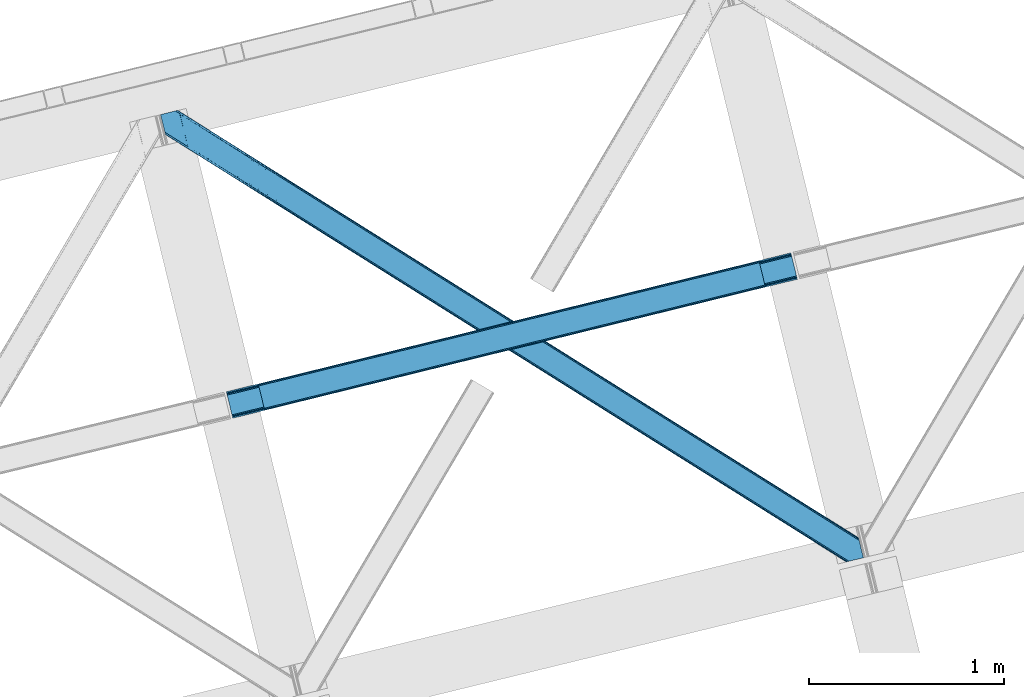
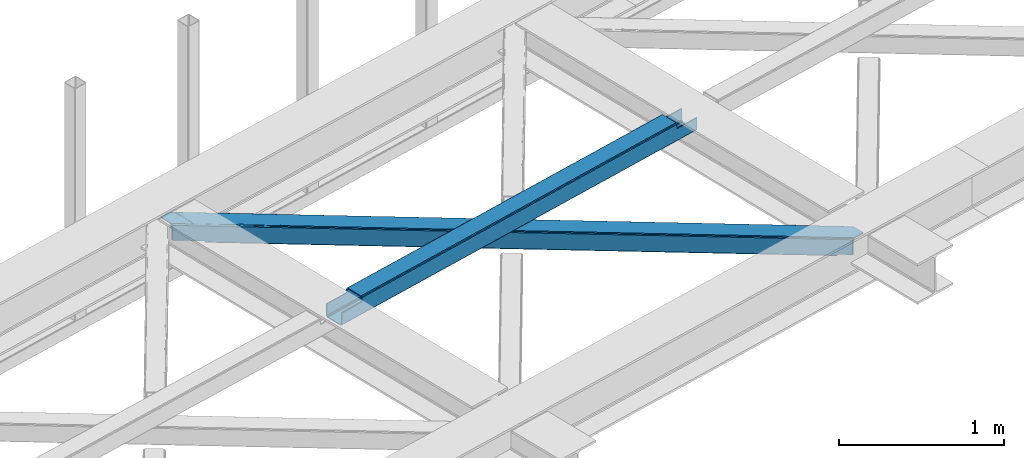
# One storey, part 22 of 67: 1 beam, 1 member.
"""IFC4 building model written with IfcOpenShell, lengths in millimetres."""

from ifc_helpers import new_model, entity, si_unit, converted_unit, derived_unit, direction, frame, origin, place, context, subcontext, project, spatial, triangles, polygons, material, type_object, element, save


model = new_model("IFC4")

# Units and contexts
model_context = context("Model", 3, precision=0.01, world=origin(), true_north=direction((6.12303176911189e-17, 1.0)))
plan_context = context("Plan", 3, precision=0.01, world=origin(), true_north=direction((6.12303176911189e-17, 1.0)))
body_context = subcontext(model_context, "Body", "Model", "MODEL_VIEW")
ifc_project = project(units=[si_unit("LENGTHUNIT", "METRE", prefix="MILLI"), si_unit("AREAUNIT", "SQUARE_METRE"), si_unit("VOLUMEUNIT", "CUBIC_METRE"), converted_unit("PLANEANGLEUNIT", "DEGREE", entity("IfcRatioMeasure", 0.0174532925199433), si_unit("PLANEANGLEUNIT", "RADIAN"), dimensions=[0, 0, 0, 0, 0, 0, 0]), si_unit("MASSUNIT", "GRAM", prefix="KILO"), derived_unit("MASSDENSITYUNIT", [(si_unit("MASSUNIT", "GRAM", prefix="KILO"), 1), (si_unit("LENGTHUNIT", "METRE"), -3)]), derived_unit("MOMENTOFINERTIAUNIT", [(si_unit("LENGTHUNIT", "METRE"), 4)]), si_unit("TIMEUNIT", "SECOND"), si_unit("FREQUENCYUNIT", "HERTZ"), si_unit("THERMODYNAMICTEMPERATUREUNIT", "DEGREE_CELSIUS"), derived_unit("THERMALTRANSMITTANCEUNIT", [(si_unit("MASSUNIT", "GRAM", prefix="KILO"), 1), (si_unit("THERMODYNAMICTEMPERATUREUNIT", "KELVIN"), -1), (si_unit("TIMEUNIT", "SECOND"), -3)]), derived_unit("VOLUMETRICFLOWRATEUNIT", [(si_unit("LENGTHUNIT", "METRE"), 3), (si_unit("TIMEUNIT", "SECOND"), -1)]), derived_unit("MASSFLOWRATEUNIT", [(si_unit("MASSUNIT", "GRAM", prefix="KILO"), 1), (si_unit("TIMEUNIT", "SECOND"), -1)]), derived_unit("ROTATIONALFREQUENCYUNIT", [(si_unit("TIMEUNIT", "SECOND"), -1)]), si_unit("ELECTRICCURRENTUNIT", "AMPERE"), si_unit("ELECTRICVOLTAGEUNIT", "VOLT"), si_unit("POWERUNIT", "WATT"), si_unit("FORCEUNIT", "NEWTON", prefix="KILO"), si_unit("ILLUMINANCEUNIT", "LUX"), si_unit("LUMINOUSFLUXUNIT", "LUMEN"), si_unit("LUMINOUSINTENSITYUNIT", "CANDELA"), derived_unit("USERDEFINED", [(si_unit("MASSUNIT", "GRAM", prefix="KILO"), -1), (si_unit("LENGTHUNIT", "METRE"), -2), (si_unit("TIMEUNIT", "SECOND"), 3), (si_unit("LUMINOUSFLUXUNIT", "LUMEN"), 1)]), derived_unit("LINEARVELOCITYUNIT", [(si_unit("LENGTHUNIT", "METRE"), 1), (si_unit("TIMEUNIT", "SECOND"), -1)]), si_unit("PRESSUREUNIT", "PASCAL"), derived_unit("USERDEFINED", [(si_unit("LENGTHUNIT", "METRE"), -2), (si_unit("MASSUNIT", "GRAM", prefix="KILO"), 1), (si_unit("TIMEUNIT", "SECOND"), -2)]), derived_unit("LINEARFORCEUNIT", [(si_unit("MASSUNIT", "GRAM", prefix="KILO"), 1), (si_unit("LENGTHUNIT", "METRE"), 1), (si_unit("TIMEUNIT", "SECOND"), -2), (si_unit("LENGTHUNIT", "METRE"), -1)]), derived_unit("PLANARFORCEUNIT", [(si_unit("MASSUNIT", "GRAM", prefix="KILO"), 1), (si_unit("LENGTHUNIT", "METRE"), 1), (si_unit("TIMEUNIT", "SECOND"), -2), (si_unit("LENGTHUNIT", "METRE"), -2)])], contexts=[model_context, plan_context])

# Site, building, storey
site_placement = place(None, origin())
site = spatial("IfcSite", under=ifc_project, at=site_placement, CompositionType="ELEMENT")
building_placement = place(site_placement, origin())
building = spatial("IfcBuilding", under=site, at=building_placement, CompositionType="ELEMENT")
storey_placement = place(building_placement, frame((0.0, 0.0, 19800.0)))
storey = spatial("IfcBuildingStorey", under=building, at=storey_placement, CompositionType="ELEMENT", Elevation=19800.0)

# Beam
ifc_material = material(Name="Metal painted (White)")
beam_type = type_object("IfcBeamType", PredefinedType="BEAM")
beam_placement = place(storey_placement, frame((-54824.1636583396, 5769.03863543557, 3967.02213739951)))
element("IfcBeam", 1, at=beam_placement, inside=storey, type_object=beam_type, material=ifc_material, ObjectType="Steel Beam", PredefinedType="BEAM", context=body_context, shape_type="Tessellation", body=[
    polygons([(195.600194800813, 47.1939241264222, 116.42075398189), (195.284716026293, 48.4881398473771, 123.117713426564), (2768.48559452429, 681.870165407988, 122.252244531349), (2768.8010732988, 680.575949687039, 115.555285086674), (194.386308486354, 52.1737543987821, 128.795119546125), (2767.58718698436, 685.555779959382, 127.92965065091), (193.041746584857, 57.68966637537, 132.588638724685), (2766.24262508285, 691.071691935976, 131.723169829474), (191.455727682833, 64.1961281805606, 133.920742055655), (2764.65660618083, 697.578153741184, 133.055273160444), (169.904498669375, 152.607589262092, 133.920675186106), (2743.10537716737, 785.989614822718, 133.055206290887), (168.318479767342, 159.11405106732, 132.588562012879), (2741.51935826533, 792.496076627927, 131.723093117668), (166.973917865845, 164.62996304391, 128.795034490451), (2740.17479636384, 798.011988604516, 127.92956559524), (166.075510325905, 168.315577595309, 123.117622795697), (2739.2763888239, 801.697603155919, 122.25215390049), (165.760031551394, 169.609793316236, 116.420661393285), (2738.9609100494, 802.991818876856, 115.55519249807), (2737.3031232022, 809.792700498515, 100.498086491912), (2737.3031232022, 809.792700498512, 122.555187727575), (2737.61860197673, 808.498484777561, 129.252149129995), (2738.51700951666, 804.812870226159, 134.929560824745), (2739.86157141815, 799.296958249569, 138.723088347173), (2741.44759032019, 792.790496444372, 140.055201520396), (2766.31439302802, 690.777272119526, 140.055278677568), (2767.90041193007, 684.270810314297, 138.723175346603), (2769.24497383155, 678.754898337704, 134.929656168038), (2770.14338137148, 675.069283786305, 129.252250048477), (2770.45886014632, 673.775068064077, 122.555290603803), (2770.458860146, 673.775068065387, 100.498086491912), (2768.8010732988, 680.575949687043, 100.498086491912), (2738.9609100494, 802.991818876859, 100.498086491912), (165.760031551394, 169.609793316234, 101.477862600484), (195.600194800804, 47.19392412642, 101.477862600484), (197.257981650611, 40.3930424941034, 101.477862600484), (197.257981647995, 40.3930425047642, 123.420759499018), (196.942502873484, 41.6872582257018, 130.117718943693), (196.044095333544, 45.3728727771036, 135.795125063254), (194.699533432056, 50.8887847536925, 139.588644241814), (193.113514530023, 57.3952465589037, 140.920747572779), (168.246711822184, 159.408470883749, 140.920670415607), (166.660692920151, 165.91493268896, 139.588557242389), (165.316131018655, 171.430844665549, 135.795029719961), (164.417723478715, 175.116459216949, 130.117618025206), (164.102244704213, 176.410674937892, 123.420656622786), (164.102244704204, 176.410674937891, 101.477862600484), (2932.90331800302, 720.968992071854, 99.4980864919168), (2932.90331800301, 720.968992071855, 24.5000861794985), (31.4979500966005, 6.80088174161364, 25.4759431828536), (31.4979500966005, 6.80088174161039, 100.477862600484), (194.629175601386, 46.954912041303, 100.477862600484), (1.65778684719041, 129.216750931428, 25.4758505942489), (2903.0631547536, 843.38486126167, 24.4999935908851), (2903.06315475361, 843.384861261669, 99.4980864919168), (2739.93192924883, 803.230830961977, 99.4980864919125), (1.65778684719041, 129.216750931425, 100.477862600484), (2934.56110484841, 714.168110457476, 17.5000909499932), (2934.56110485024, 714.168110450053, 99.4980864919168), (2771.42987934576, 674.014080149109, 99.4980864919125), (33.1557369624336, 4.30807858720073e-08, 100.477862600484), (33.1557369474987, 1.04891924479489e-07, 18.4759479533483), (2901.40536790643, 850.185742883325, 99.4980864919125), (2901.40536790642, 850.185742883325, 17.4999880737653), (-8.66293703438714e-12, 136.017632553082, 18.4758450771204), (-8.66293703438714e-12, 136.017632553081, 100.477862600484), (163.131225504786, 176.171662852774, 100.477862600484), (2769.77209249823, 680.814961772162, 99.4980864919168), (2738.27414240164, 810.031712583632, 99.4980864919125), (2903.37863352811, 842.090645540732, 17.8030341462194), (2904.27704106805, 838.405030989331, 12.125628026654), (2905.62160296955, 832.88911901274, 8.33210884809829), (2907.20762187157, 826.382657207531, 7.00000551712847), (2928.75885088503, 737.971196125998, 7.00007238668162), (2930.34486978706, 731.464734320788, 8.33218555990442), (2931.68943168856, 725.948822344197, 12.1257130823282), (2932.5878392285, 722.263207792796, 17.8031247770826), (2934.24562607568, 715.46232617116, 10.8031295475774), (2933.34721853574, 719.147940722563, 5.12571785282298), (2932.00265663425, 724.663852699151, 1.33219033039485), (2930.41663773223, 731.170314504341, 7.715717638348e-05), (2905.54983502439, 833.183538829187, 4.33146851719357e-12), (2903.96381612235, 839.690000634412, 1.33210333096982), (2902.61925422086, 845.205912611001, 5.12562250952989), (2901.72084668092, 848.891527162403, 10.8030286290909), (196.286962448568, 40.1540304196461, 100.477862600484), (164.789012351976, 169.370781231118, 100.477862600484), (27.3534829786202, 23.8030857957542, 7.97592939004109), (28.9395018806444, 17.2966239905647, 9.30804256325955), (30.2840637821412, 11.7807120139757, 13.1015700856834), (31.1824713220808, 8.09509746257289, 18.7789817804377), (1.97326562169287, 127.922535210498, 18.7788911495702), (2.87167316163245, 124.236920659101, 13.1014850300135), (4.21623506312922, 118.72100868251, 9.30796585145342), (5.80225396516212, 112.214546877286, 7.9758625204836), (0.315478774519784, 134.723416832145, 11.7788856324504), (1.21388631445936, 131.037802280743, 6.10147951288935), (2.5584482159388, 125.521890304153, 2.30796033432496), (4.1444671179717, 119.015428498944, 0.975857003359465), (29.0112698258106, 17.0022041740973, 0.975934160527186), (30.5972887278435, 10.4957423688883, 2.30804733374998), (31.9418506293316, 4.97983039229717, 6.10157485618245), (32.8402581692712, 1.2942158408987, 11.7789865509282)], [[[1, 2, 3, 4]], [[2, 5, 6, 3]], [[5, 7, 8, 6]], [[7, 9, 10, 8]], [[11, 12, 10, 9]], [[11, 13, 14, 12]], [[13, 15, 16, 14]], [[15, 17, 18, 16]], [[17, 19, 20, 18]], [[21, 22, 23, 24, 25, 26, 27, 28, 29, 30, 31, 32, 33, 4, 3, 6, 8, 10, 12, 14, 16, 18, 20, 34]], [[35, 19, 17, 15, 13, 11, 9, 7, 5, 2, 1, 36, 37, 38, 39, 40, 41, 42, 43, 44, 45, 46, 47, 48]], [[42, 41, 28, 27]], [[41, 40, 29, 28]], [[40, 39, 30, 29]], [[39, 38, 31, 30]], [[27, 26, 43, 42]], [[47, 46, 23, 22]], [[46, 45, 24, 23]], [[45, 44, 25, 24]], [[44, 43, 26, 25]], [[33, 49, 50, 51, 52, 53, 1, 4]], [[54, 55, 56, 57, 20, 19, 35, 58]], [[59, 60, 61, 31, 38, 37, 62, 63]], [[64, 65, 66, 67, 68, 47, 22, 21]], [[61, 60, 49, 69]], [[64, 70, 57, 56]], [[65, 64, 56, 55, 71, 72, 73, 74, 75, 76, 77, 78, 50, 49, 60, 59, 79, 80, 81, 82, 83, 84, 85, 86]], [[87, 53, 52, 62]], [[67, 58, 88, 68]], [[89, 90, 76, 75]], [[90, 91, 77, 76]], [[91, 92, 78, 77]], [[92, 51, 50, 78]], [[54, 93, 71, 55]], [[93, 94, 72, 71]], [[94, 95, 73, 72]], [[95, 96, 74, 73]], [[89, 75, 74, 96]], [[66, 97, 98, 99, 100, 101, 102, 103, 104, 63, 62, 52, 51, 92, 91, 90, 89, 96, 95, 94, 93, 54, 58, 67]], [[63, 104, 79, 59]], [[104, 103, 80, 79]], [[103, 102, 81, 80]], [[102, 101, 82, 81]], [[100, 99, 84, 83]], [[99, 98, 85, 84]], [[98, 97, 86, 85]], [[97, 66, 65, 86]], [[83, 82, 101, 100]]], closed=False),
])

# Member
member_type = type_object("IfcMemberType", PredefinedType="BRACE")
member_placement = place(storey_placement, frame((-55162.1911010742, 5030.29760742188, 3823.99987792968)))
element("IfcMember", 2, at=member_placement, inside=storey, type_object=member_type, ObjectType="Steel Horizontal Brace", PredefinedType="BRACE", context=body_context, shape_type="Tessellation", body=[
    triangles([(207.722204589845, 2101.81647491455, 0.0), (172.045312499999, 2248.17905273438, 0.0), (3404.49451904296, 219.293591308594, 0.0), (3440.17141113281, 72.9304321289064, 0.0), (202.587634277341, 2097.1307144165, 1.33247680664135), (208.512854003908, 2098.5748123169, 0.155804443358647), (3442.44569091796, 63.5955368041996, 1.33247680664135), (3445.6640991211, 50.3934356689451, 10.8039916992202), (3446.115234375, 48.5365722656252, 17.5012573242202), (187.951318359374, 2093.56290893555, 17.5012573242202), (189.755859375, 2094.00299835205, 10.8039916992202), (3444.37580566406, 55.6814849853517, 5.12526855468968), (194.895080566406, 2095.25582885742, 5.12526855468968), (3405.09448242188, 238.005821228027, 10.8039916992202), (3400.22036132812, 236.818684387207, 5.32758178711083), (167.840917968751, 2265.42858123779, 5.12526855468968), (166.547973632813, 2270.71604919434, 10.8039916992202), (3400.29942626953, 236.497773742676, 5.1694519042976), (3402.2155883789, 228.628486633301, 1.33247680664135), (169.766381835936, 2257.51452941895, 1.33247680664135), (3406.8990234375, 238.445910644531, 17.5012573242202), (166.096838378908, 2272.57291259766, 17.5012573242202), (3401.19239501953, 237.055297851563, 18.5197998046897), (3406.8990234375, 238.445910644531, 18.5197998046897), (3400.50406494141, 236.887866210937, 18.2267944335945), (3400.82032470703, 236.964605712891, 18.4453857421868), (3400.29477539063, 236.836706542969, 17.9035583496116), (3400.22036132812, 236.818684387207, 17.5198608398459), (3402.04350585937, 231.951539611817, 18.4453857421868), (3401.8388671875, 231.936424255371, 18.1454040527351), (3401.62027587891, 231.920146179199, 17.8198425292976), (3401.61097412109, 231.919564819336, 17.8058898925774), (3401.42028808594, 231.905612182617, 17.5198608398459), (3402.49929199219, 231.698648071289, 18.5197998046897), (3586.90198974609, 125.462690734864, 18.5197998046897), (3589.64135742188, 114.236631774903, 18.5197998046897), (204.382873535156, 2097.56789703369, 12.1248413085959), (208.512854003908, 2098.5748123169, 9.69243164062573), (199.652929687501, 2096.41506042481, 17.9802978515618), (198.425097656247, 2096.11624145508, 19.5011352539077), (187.951318359374, 2093.56290893555, 19.5011352539077), (25.310083007811, 2195.64679412842, 19.5011352539077), (22.6823364257798, 2206.42171783447, 19.5011352539077), (3437.79016113281, 82.6879760742186, 6.99957275390625), (3404.59683837891, 218.870942687989, 8.3320495605476), (3402.66672363281, 226.784994506836, 12.1248413085959), (3406.87111816406, 209.536047363282, 6.99957275390625), (3443.24564208985, 60.3184112548834, 17.5198608398459), (3441.99920654297, 65.4390289306639, 12.1248413085959), (3446.115234375, 48.5365722656252, 17.5198608398459), (3440.06909179688, 73.3530807495117, 8.3320495605476), (1232.86428222656, 1574.07891998291, 6.99957275390625), (640.588806152344, 1945.82774047852, 6.99957275390625), (602.805065917964, 1862.1026184082, 6.99957275390625), (1195.07589111328, 1490.35496063232, 6.99957275390625), (1825.13975830078, 1202.32951812744, 6.99957275390625), (1787.3513671875, 1118.60788421631, 6.99957275390625), (205.340954589839, 2111.57401885986, 6.99957275390625), (174.421911621095, 2238.42150878906, 6.99957275390625), (2971.89766845703, 375.113150024415, 6.99957275390625), (3009.69071044922, 458.831295776367, 6.99957275390625), (2379.62219238281, 746.860807800294, 6.99957275390625), (2417.415234375, 830.580697631836, 6.99957275390625), (168.836206054686, 2261.33697052002, 18.501196289064), (166.096838378908, 2272.57291259766, 18.501196289064), (168.971081542964, 2260.78584136963, 17.8803039550803), (170.217517089841, 2255.67045593262, 12.1248413085959), (172.147631835935, 2247.75698547363, 8.3320495605476), (207.559423828126, 2102.47631835938, 8.8831787109375), (3444.59439697266, 58.9998870849613, 18.5197998046897), (3447.33376464844, 47.7738281250004, 18.5197998046897), (3447.04541015625, 47.9546310424803, 18.2849304199226), (3444.26883544922, 59.317890930176, 18.2802795410171), (3446.72449951171, 48.1552001953123, 18.0198303222678), (3443.92001953125, 59.6591491699219, 18.0198303222678), (3446.40358886719, 48.356350708008, 17.757055664064), (3443.63166503906, 59.9422714233397, 17.8058898925774), (3443.57120361328, 60.0009887695314, 17.7617065429695), (3534.35635986328, 2.65972137451172, 18.5197998046897), (3523.44539794922, 0.0, 18.5197998046897), (2962.59125976562, 360.290798950195, 24.5008300781265), (2963.30284423828, 361.419218444825, 17.8035644531265), (3532.92854003906, 2.31206817626935, 24.5008300781265), (2965.31667480469, 364.63239440918, 12.1248413085959), (596.224072265621, 1851.62186279297, 12.1248413085959), (599.242492675781, 1856.43029022217, 8.3320495605476), (594.21024169922, 1848.40868682861, 17.8035644531265), (593.498657226563, 1847.28026733398, 24.5008300781265), (22.9334838867144, 2205.40433807373, 24.5008300781265), (2968.33509521484, 369.440821838379, 8.3320495605476), (2370.32043457031, 732.038456726074, 24.5008300781265), (2371.02736816406, 733.16629486084, 17.8035644531265), (1778.75654296875, 1104.91395263672, 17.8035644531265), (1778.0449584961, 1103.78553314209, 24.5008300781265), (1186.48106689453, 1476.6616104126, 17.8035644531265), (1185.77413330078, 1475.53319091797, 24.5008300781265), (2373.04584960937, 736.379470825195, 12.1248413085959), (1780.77037353515, 1108.12712860107, 12.1248413085959), (1188.49954833985, 1479.87420501709, 12.1248413085959), (2376.06427001953, 741.188479614258, 8.3320495605476), (1783.78879394531, 1112.93555603027, 8.3320495605476), (1191.51796875, 1484.68321380615, 8.3320495605476), (2965.14924316406, 350.42105255127, 122.499499511719), (2371.32502441406, 723.143650817871, 122.499499511719), (3523.44539794922, 0.0, 122.499499511719), (1777.49615478516, 1095.86624908447, 122.499499511719), (1183.67193603516, 1468.58884735107, 122.499499511719), (589.843066406247, 1841.31144561768, 122.499499511719), (25.310083007811, 2195.64679412842, 122.499499511719), (3532.92854003906, 2.31206817626935, 115.499926757813), (22.9334838867144, 2205.40433807373, 115.499926757813), (3534.73308105468, 2.75215759277398, 122.197192382813), (22.4776977539077, 2207.26120147705, 122.197192382813), (3539.876953125, 4.00498809814508, 127.873590087893), (21.1894042968706, 2212.54925079346, 127.873590087893), (3547.56485595703, 5.87987365722711, 131.668707275392), (19.2592895507769, 2220.4633026123, 131.668707275392), (3556.63872070312, 8.09194793701226, 133.001184082033), (16.9850097656235, 2229.79819793701, 133.001184082033), (3525.24993896484, 0.440089416503724, 129.196765136719), (3530.38916015625, 1.69291992187482, 134.87548828125), (3547.15557861328, 5.77987976074201, 140.00075683594), (3612.21207275391, 21.6376327514654, 140.00075683594), (3612.21207275391, 21.6376327514654, 133.001184082033), (3538.08171386718, 3.56780548095685, 138.668280029298), (168.515295410158, 2261.63113861084, 18.7407165527366), (165.808483886714, 2272.75313415527, 18.7360656738274), (168.171130371091, 2261.94914245605, 19.0011657714858), (165.492224121095, 2272.95428466797, 19.0011657714858), (167.826965332031, 2262.26714630127, 19.2592895507805), (165.17131347656, 2273.15543518066, 19.2639404296897), (167.510705566405, 2262.56131439209, 19.5011352539077), (164.882958984374, 2273.33565673828, 19.5011352539077), (78.2975463867188, 2318.55673370361, 19.5011352539077), (88.7666748046831, 2321.11006622314, 19.5011352539077), (649.183630371095, 1959.52167205811, 17.8035644531265), (3018.28553466796, 472.525227355957, 17.8035644531265), (3016.26705322265, 469.312632751465, 12.1248413085959), (3018.99246826172, 473.653646850586, 24.5008300781265), (3589.2832397461, 115.705146789551, 24.5008300781265), (649.890563964844, 1960.65009155273, 24.5008300781265), (79.2835327148423, 2318.79799804688, 24.5008300781265), (3013.2486328125, 464.503623962402, 8.3320495605476), (644.146728515625, 1951.50006866455, 8.3320495605476), (647.165148925778, 1956.30849609375, 12.1248413085959), (2420.97315673828, 836.253025817871, 8.3320495605476), (1828.69768066406, 1208.00184631348, 8.3320495605476), (1236.42220458984, 1579.75124816895, 8.3320495605476), (2423.99157714844, 841.061453247071, 12.1248413085959), (1831.71610107422, 1212.81027374268, 12.1248413085959), (1239.440625, 1584.55967559815, 12.1248413085959), (2426.01005859375, 844.274629211426, 17.8035644531265), (1833.73458251953, 1216.02344970703, 17.8035644531265), (1241.45910644531, 1587.7728515625, 17.8035644531265), (2426.7169921875, 845.403048706055, 24.5008300781265), (1834.44151611328, 1217.15186920166, 24.5008300781265), (1242.16604003906, 1588.90068969727, 24.5008300781265), (1247.70988769531, 1593.6864440918, 122.499499511719), (653.815905761716, 1966.45090026855, 122.499499511719), (1841.59921875, 1220.9225692749, 122.499499511719), (3586.90198974609, 125.462690734864, 122.499499511719), (2435.4932006836, 848.158694458008, 122.499499511719), (3029.38718261719, 475.394819641114, 122.499499511719), (88.7666748046831, 2321.11006622314, 122.499499511719), (3591.02266845703, 108.560234069824, 127.873590087893), (3588.64606933593, 118.317778015137, 134.87548828125), (3590.57618408203, 110.403726196289, 138.668280029298), (3592.95278320312, 100.646182250976, 131.668707275392), (3595.22706298828, 91.3112869262695, 133.001184082033), (3592.85046386719, 101.068830871583, 140.00075683594), (3589.734375, 113.848283386231, 122.197192382813), (3587.3577758789, 123.605827331543, 129.196765136719), (3589.2832397461, 115.705146789551, 115.499926757813), (55.5733520507783, 2313.01811828613, 133.001184082033), (0.0, 2299.47185211182, 133.001184082033), (79.2835327148423, 2318.79799804688, 115.499926757813), (64.647216796875, 2315.23019256592, 131.668707275392), (72.3397705078096, 2317.105078125, 127.873590087893), (77.4789916992158, 2318.35790863037, 122.197192382813), (76.0651245117188, 2318.01316223145, 138.000878906252), (81.8229125976577, 2319.41714630127, 134.87548828125), (86.962133789064, 2320.66997680664, 129.196765136719), (0.0, 2299.47185211182, 138.000878906252), (24.8589477539063, 2197.50365753174, 129.196765136719), (23.5706542968765, 2202.79228820801, 134.87548828125), (22.1242309570298, 2208.71692657471, 138.000878906252), (98.1940063476577, 2304.12389373779, 138.000878906252), (139.391491699214, 2135.11211700439, 138.000878906252), (599.144824218747, 1856.13379669189, 140.00075683594), (139.828674316406, 2137.54627075195, 139.000817871096), (140.051916503908, 2136.3818069458, 138.668280029298), (137.847399902341, 2145.67426300049, 140.00075683594), (592.568481445313, 1845.65304107666, 134.87548828125), (139.805419921875, 2135.02549438477, 138.075292968751), (595.586901855466, 1850.46146850586, 138.668280029298), (139.921691894531, 2135.65975799561, 138.352020263672), (140.037963867188, 2136.29576568604, 138.631072998047), (2974.45565185547, 365.243403625488, 140.00075683594), (2970.89307861328, 359.571075439453, 138.668280029298), (2967.87465820312, 354.762648010254, 134.87548828125), (2965.86082763672, 351.549472045898, 129.196765136719), (590.549999999996, 1842.4398651123, 129.196765136719), (2372.03195800781, 724.272070312501, 129.196765136719), (1778.2030883789, 1096.9946685791, 129.196765136719), (1184.3788696289, 1469.7172668457, 129.196765136719), (2374.05043945312, 727.485246276856, 134.87548828125), (1780.22156982421, 1100.20784454346, 134.87548828125), (1186.39270019531, 1472.93044281006, 134.87548828125), (2377.06885986328, 732.293673706055, 138.668280029298), (1783.23999023438, 1105.01627197266, 138.668280029298), (1189.41112060547, 1477.73887023926, 138.668280029298), (2380.62678222656, 737.96600189209, 140.00075683594), (1786.79791259766, 1110.68860015869, 140.00075683594), (1192.97369384766, 1483.41119842529, 140.00075683594), (651.090490722658, 1962.10930480957, 134.87548828125), (98.7102539062471, 2303.62683105469, 138.075292968751), (99.1985961914033, 2302.47515716553, 138.384576416018), (648.072070312497, 1957.30087738037, 138.668280029298), (99.6032226562456, 2301.53800506592, 138.633398437501), (644.514147949216, 1951.62854919434, 140.00075683594), (100.189233398436, 2300.16483306885, 139.000817871096), (102.170507812501, 2292.03684082031, 140.00075683594), (3028.68024902343, 474.266400146485, 129.196765136719), (3026.66176757812, 471.053224182129, 134.87548828125), (3023.64334716797, 466.24479675293, 138.668280029298), (3020.08542480469, 460.572468566895, 140.00075683594), (653.108972167967, 1965.32248077393, 129.196765136719), (2429.74936523438, 839.008671569824, 138.668280029298), (2426.1914428711, 833.336343383789, 140.00075683594), (1835.86003417968, 1211.77254638672, 138.668280029298), (1832.2974609375, 1206.10021820068, 140.00075683594), (1241.96605224609, 1584.53700256348, 138.668280029298), (1238.40347900391, 1578.86467437744, 140.00075683594), (2432.76778564453, 843.817680358887, 134.87548828125), (1838.87845458985, 1216.58155517578, 134.87548828125), (1244.98447265625, 1589.34542999268, 134.87548828125), (2434.78626708984, 847.030274963379, 129.196765136719), (1840.89228515625, 1219.79473114014, 129.196765136719), (1247.00295410156, 1592.55860595703, 129.196765136719)], [[1, 2, 3], [3, 4, 1], [5, 6, 4], [4, 7, 5], [8, 9, 10], [10, 11, 8], [12, 8, 11], [11, 13, 12], [7, 12, 13], [13, 5, 7], [6, 1, 4], [14, 15, 16], [16, 17, 14], [18, 19, 20], [19, 3, 2], [2, 20, 19], [20, 16, 18], [15, 18, 16], [21, 14, 17], [17, 22, 21], [23, 21, 24], [25, 23, 26], [23, 25, 27], [23, 27, 28], [21, 23, 28], [28, 15, 14], [14, 21, 28], [26, 29, 30], [25, 30, 31], [27, 32, 33], [27, 31, 32], [33, 28, 27], [31, 27, 25], [30, 25, 26], [23, 34, 29], [29, 26, 23], [34, 24, 35], [24, 34, 23], [35, 36, 34], [37, 38, 5], [37, 5, 13], [13, 11, 39], [38, 6, 5], [39, 37, 13], [11, 10, 40], [41, 40, 10], [11, 40, 39], [42, 43, 40], [40, 41, 42], [3, 44, 4], [45, 19, 46], [33, 15, 28], [18, 33, 46], [33, 18, 15], [3, 19, 45], [46, 19, 18], [3, 47, 44], [45, 47, 3], [8, 48, 9], [48, 12, 49], [12, 48, 8], [50, 9, 48], [49, 7, 51], [51, 4, 44], [4, 51, 7], [49, 12, 7], [52, 53, 54], [54, 55, 52], [55, 56, 52], [56, 55, 57], [53, 58, 54], [53, 59, 58], [60, 61, 62], [61, 60, 47], [44, 47, 60], [63, 62, 61], [57, 63, 56], [62, 63, 57], [17, 22, 64], [22, 65, 64], [66, 17, 64], [66, 16, 17], [67, 16, 66], [20, 67, 68], [67, 20, 16], [2, 20, 68], [68, 59, 2], [69, 38, 6], [69, 1, 58], [1, 59, 58], [59, 1, 2], [69, 6, 1], [70, 71, 72], [72, 73, 70], [73, 72, 74], [74, 75, 73], [75, 76, 77], [75, 74, 76], [76, 78, 77], [78, 76, 50], [50, 48, 78], [71, 70, 79], [79, 80, 71], [81, 70, 73], [73, 82, 81], [73, 75, 82], [75, 77, 82], [83, 79, 70], [70, 81, 83], [82, 77, 78], [78, 84, 82], [78, 48, 84], [48, 49, 84], [54, 58, 69], [85, 86, 38], [86, 69, 38], [87, 85, 37], [88, 87, 39], [39, 40, 88], [88, 40, 89], [43, 89, 40], [37, 39, 87], [38, 37, 85], [69, 86, 54], [51, 44, 90], [60, 90, 44], [49, 51, 84], [90, 84, 51], [81, 82, 91], [92, 91, 82], [91, 92, 93], [93, 94, 91], [94, 93, 95], [95, 96, 94], [96, 95, 87], [87, 88, 96], [82, 84, 97], [97, 92, 82], [92, 97, 98], [98, 93, 92], [93, 98, 99], [99, 95, 93], [95, 99, 85], [85, 87, 95], [84, 90, 100], [100, 97, 84], [97, 100, 101], [101, 98, 97], [98, 101, 102], [102, 99, 98], [99, 102, 86], [86, 85, 99], [90, 60, 62], [62, 100, 90], [100, 62, 57], [57, 101, 100], [101, 57, 55], [55, 102, 101], [102, 55, 54], [54, 86, 102], [9, 103, 104], [71, 105, 72], [71, 80, 105], [105, 74, 72], [50, 105, 103], [50, 76, 105], [76, 74, 105], [9, 50, 103], [106, 10, 9], [10, 107, 108], [109, 41, 108], [106, 107, 10], [106, 9, 104], [10, 108, 41], [42, 41, 109], [81, 110, 83], [110, 81, 91], [110, 94, 111], [94, 110, 91], [88, 89, 111], [96, 111, 94], [111, 96, 88], [112, 110, 111], [111, 113, 112], [114, 112, 113], [113, 115, 114], [116, 114, 115], [115, 117, 116], [118, 116, 117], [117, 119, 118], [112, 120, 121], [118, 122, 123], [123, 124, 118], [118, 116, 122], [116, 125, 122], [114, 125, 116], [121, 125, 114], [112, 105, 120], [110, 105, 112], [121, 114, 112], [80, 83, 79], [110, 80, 105], [83, 80, 110], [65, 64, 126], [126, 127, 65], [127, 126, 128], [128, 129, 127], [129, 128, 130], [130, 131, 129], [131, 130, 132], [132, 133, 131], [134, 135, 133], [133, 132, 134], [136, 66, 67], [137, 138, 33], [138, 46, 33], [139, 29, 34], [34, 140, 139], [34, 36, 140], [139, 137, 32], [32, 31, 139], [30, 29, 139], [139, 31, 30], [141, 130, 128], [141, 132, 130], [128, 136, 141], [64, 136, 126], [128, 126, 136], [64, 66, 136], [132, 141, 142], [142, 134, 132], [33, 32, 137], [45, 46, 143], [138, 143, 46], [47, 45, 61], [143, 61, 45], [53, 144, 59], [68, 59, 144], [144, 145, 68], [67, 68, 145], [67, 145, 136], [61, 143, 63], [146, 63, 143], [63, 146, 147], [147, 56, 63], [56, 147, 148], [148, 52, 56], [52, 148, 144], [144, 53, 52], [143, 138, 146], [149, 146, 138], [146, 149, 147], [150, 147, 149], [147, 150, 148], [151, 148, 150], [148, 151, 144], [145, 144, 151], [138, 137, 152], [152, 149, 138], [149, 152, 153], [153, 150, 149], [150, 153, 154], [154, 151, 150], [151, 154, 136], [136, 145, 151], [137, 139, 152], [155, 152, 139], [152, 155, 153], [156, 153, 155], [153, 156, 154], [157, 154, 156], [154, 157, 136], [141, 136, 157], [158, 22, 159], [22, 158, 160], [161, 35, 24], [21, 160, 162], [21, 163, 24], [160, 21, 22], [24, 163, 161], [162, 163, 21], [164, 159, 65], [164, 65, 127], [22, 65, 159], [129, 164, 127], [164, 129, 131], [131, 133, 164], [135, 164, 133], [165, 166, 167], [165, 167, 168], [169, 168, 170], [171, 166, 165], [124, 169, 123], [170, 123, 169], [168, 167, 170], [172, 166, 171], [35, 161, 173], [140, 35, 173], [35, 140, 36], [172, 171, 161], [171, 173, 161], [119, 174, 169], [174, 119, 175], [169, 118, 119], [124, 118, 169], [156, 173, 176], [173, 155, 139], [156, 155, 173], [139, 140, 173], [157, 176, 141], [176, 157, 156], [142, 141, 176], [168, 169, 174], [174, 177, 168], [165, 168, 177], [177, 178, 165], [171, 165, 178], [178, 179, 171], [173, 171, 179], [179, 176, 173], [177, 174, 180], [181, 178, 180], [177, 180, 178], [179, 181, 182], [174, 183, 180], [174, 175, 183], [179, 178, 181], [164, 176, 179], [176, 164, 135], [142, 135, 134], [135, 142, 176], [164, 179, 182], [111, 42, 109], [184, 113, 109], [113, 184, 185], [113, 111, 109], [89, 42, 111], [43, 42, 89], [115, 113, 185], [186, 119, 117], [119, 186, 183], [183, 175, 119], [117, 115, 186], [186, 115, 185], [180, 186, 187], [180, 183, 186], [188, 187, 186], [189, 190, 191], [189, 192, 190], [193, 194, 188], [188, 185, 193], [188, 186, 185], [195, 196, 194], [195, 191, 196], [194, 193, 195], [197, 195, 189], [125, 122, 198], [198, 199, 125], [121, 125, 199], [199, 200, 121], [120, 121, 200], [200, 201, 120], [105, 120, 201], [201, 103, 105], [108, 202, 109], [184, 109, 202], [202, 193, 184], [185, 184, 193], [103, 201, 104], [203, 104, 201], [104, 203, 204], [204, 106, 104], [106, 204, 205], [205, 107, 106], [107, 205, 108], [202, 108, 205], [201, 200, 206], [206, 203, 201], [203, 206, 204], [207, 204, 206], [204, 207, 208], [208, 205, 204], [205, 208, 193], [193, 202, 205], [200, 199, 209], [209, 206, 200], [206, 209, 210], [210, 207, 206], [207, 210, 208], [211, 208, 210], [208, 211, 193], [195, 193, 211], [199, 198, 212], [212, 209, 199], [209, 212, 213], [213, 210, 209], [210, 213, 214], [214, 211, 210], [211, 214, 189], [189, 195, 211], [215, 216, 217], [217, 218, 215], [217, 219, 218], [187, 215, 181], [181, 180, 187], [219, 220, 218], [219, 221, 220], [221, 222, 220], [172, 161, 223], [163, 223, 161], [166, 172, 224], [223, 224, 172], [167, 166, 225], [224, 225, 166], [170, 167, 226], [225, 226, 167], [215, 227, 182], [182, 181, 215], [227, 159, 164], [164, 182, 227], [226, 225, 228], [228, 229, 226], [229, 228, 230], [230, 231, 229], [231, 230, 232], [232, 233, 231], [233, 232, 218], [218, 220, 233], [225, 224, 234], [234, 228, 225], [228, 234, 235], [235, 230, 228], [230, 235, 236], [236, 232, 230], [232, 236, 215], [215, 218, 232], [224, 223, 234], [237, 234, 223], [234, 237, 235], [238, 235, 237], [235, 238, 236], [239, 236, 238], [236, 239, 215], [227, 215, 239], [223, 163, 162], [162, 237, 223], [237, 162, 160], [160, 238, 237], [238, 160, 158], [158, 239, 238], [239, 158, 159], [159, 227, 239], [214, 233, 189], [233, 214, 231], [213, 231, 214], [231, 213, 229], [222, 192, 220], [189, 220, 192], [220, 189, 233], [170, 226, 198], [198, 122, 170], [123, 170, 122], [226, 212, 198], [212, 229, 213], [226, 229, 212], [197, 190, 221], [221, 219, 197], [219, 217, 194], [217, 216, 194], [222, 221, 192], [190, 192, 221]]),
])

save(model, "model.ifc")
